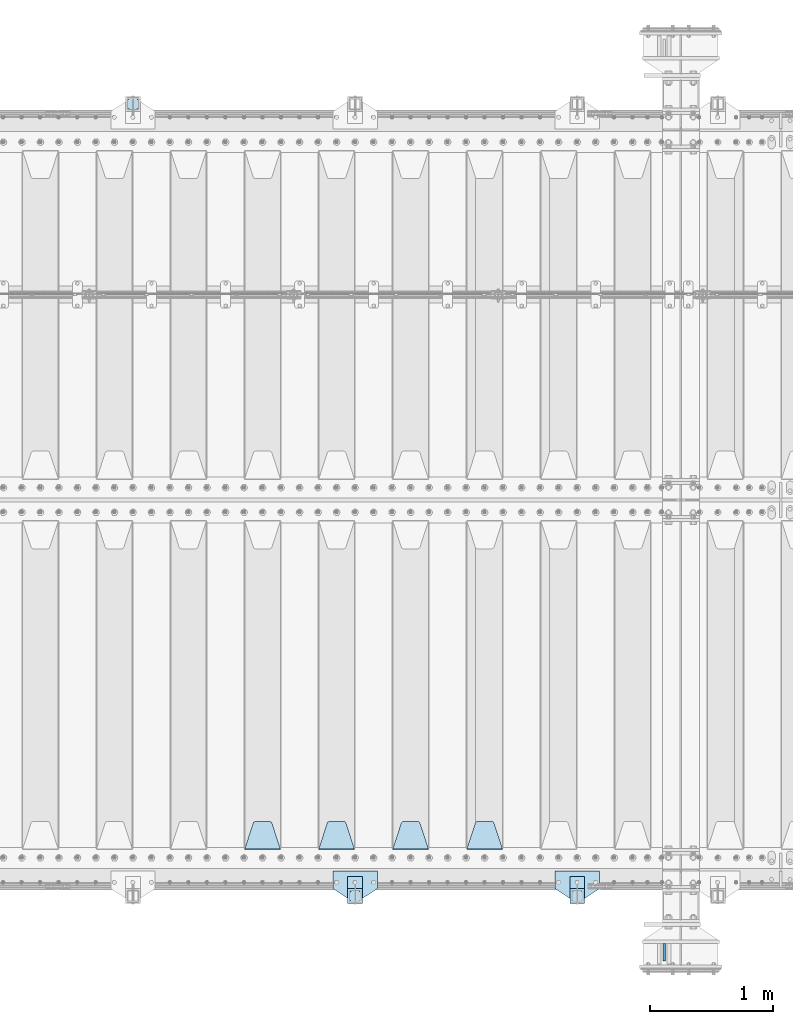
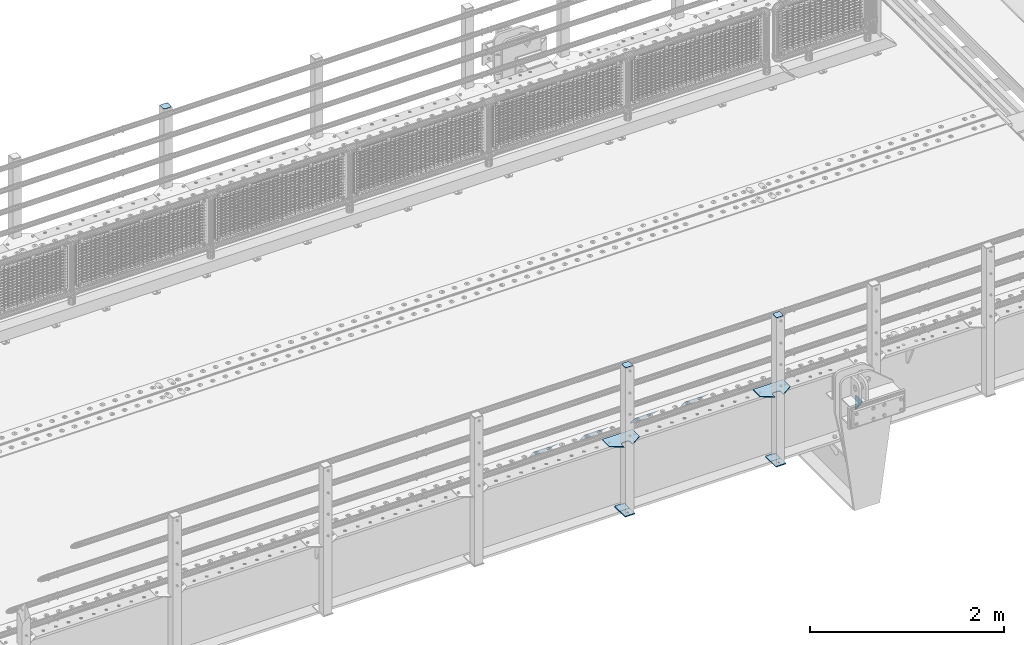
# One storey, part 164 of 193: 14 plates.
"""IFC2X3 building model written with IfcOpenShell, lengths in millimetres."""

from ifc_helpers import new_model, si_unit, frame, origin_with_axes, place, context, subcontext, project, spatial, faceted_brep, material, type_object, element, save


model = new_model("IFC2X3")

# Units and contexts
model_context = context("Model", 3, precision=1e-05, world=origin_with_axes())
body_context = subcontext(model_context, "Body", "Model", "MODEL_VIEW")
ifc_project = project(units=[si_unit("LENGTHUNIT", "METRE", prefix="MILLI"), si_unit("AREAUNIT", "SQUARE_METRE"), si_unit("VOLUMEUNIT", "CUBIC_METRE"), si_unit("MASSUNIT", "GRAM", prefix="KILO"), si_unit("TIMEUNIT", "SECOND"), si_unit("PLANEANGLEUNIT", "RADIAN"), si_unit("SOLIDANGLEUNIT", "STERADIAN"), si_unit("THERMODYNAMICTEMPERATUREUNIT", "DEGREE_CELSIUS"), si_unit("LUMINOUSINTENSITYUNIT", "LUMEN")], contexts=[model_context])

# Site, building, storey
site_placement = place(None, origin_with_axes())
site = spatial("IfcSite", under=ifc_project, at=site_placement, CompositionType="ELEMENT")
building_placement = place(site_placement, origin_with_axes())
building = spatial("IfcBuilding", under=site, at=building_placement, Name="Standard", CompositionType="ELEMENT")
storey_placement = place(building_placement, origin_with_axes())
storey = spatial("IfcBuildingStorey", under=building, at=storey_placement, Name="Undefined", CompositionType="ELEMENT", Elevation=0.0)

# Plates
ifc_material_1 = material(Name="STEEL/S355N")
plate_type_1 = type_object("IfcPlateType", PredefinedType="NOTDEFINED")
plate_1_placement = place(storey_placement, frame((-32195.5000001299, 23265.0000000057, -14.000018238301), z_axis=(0.0, 0.0, -1.0), x_axis=(0.0, 1.0, 0.0)))
element("IfcPlate", 1, at=plate_1_placement, inside=storey, type_object=plate_type_1, material=ifc_material_1, context=body_context, shape_type="Brep", body=[
    faceted_brep([(0.0, -10.0, 0.0), (140.0, -10.0, 180.0), (140.0, 10.0, 180.0), (0.0, 10.0, 0.0), (140.0, -10.0, -1.81898940354586e-12), (140.0, 10.0, -1.81898940354586e-12)], [[[0, 1, 2, 3]], [[1, 4, 5, 2]], [[4, 0, 3, 5]], [[5, 3, 2]], [[4, 1, 0]]]),
])
plate_type_2 = type_object("IfcPlateType", PredefinedType="NOTDEFINED")
plate_2_placement = place(storey_placement, frame((-33505.0, 24168.232233047, -1.76776695296758), z_axis=(0.0, 0.707106781186547, -0.707106781186548), x_axis=(-1.0, 0.0, 0.0)))
element("IfcPlate", 2, at=plate_2_placement, inside=storey, type_object=plate_type_2, material=ifc_material_1, context=body_context, shape_type="Brep", body=[
    faceted_brep([(0.0, -2.5, 0.0), (69.345504679477, -2.50000000000364, 300.171731424831), (69.345504679477, 2.49999999999636, 300.171731424831), (0.0, 2.5, 0.0), (70.9274061199576, -2.50000000000364, 304.897442415397), (70.9274061199576, 2.49999999999636, 304.897442415397), (73.3818627772307, -2.50000000000364, 309.234538108529), (73.3818627772307, 2.49999999999636, 309.234538108529), (76.6187032999551, -2.50000000000728, 313.023683126103), (76.6187032999551, 2.49999999999636, 313.023683126103), (80.5190132704993, -2.50000000000364, 316.125672595372), (80.5190132704993, 2.49999999999636, 316.125672595368), (84.9395038596849, -2.50000000000364, 318.426546230472), (84.9395038596849, 2.49999999999636, 318.426546230476), (89.7177759439219, -2.50000000000364, 319.841774983273), (89.7177759439219, 2.49999999999636, 319.841774983277), (94.678286292652, -2.50000000000364, 320.319366455074), (94.678286292652, 2.49999999999636, 320.319366455074), (195.321713707348, -2.50000000000364, 320.319366455074), (195.321713707348, 2.49999999999636, 320.319366455074), (200.282224056078, -2.50000000000364, 319.841774983273), (200.282224056078, 2.49999999999636, 319.841774983277), (205.060496140315, -2.50000000000364, 318.426546230472), (205.060496140315, 2.49999999999636, 318.426546230472), (209.480986729501, -2.50000000000364, 316.125672595372), (209.480986729501, 2.49999999999636, 316.125672595368), (213.381296700045, -2.50000000000728, 313.023683126103), (213.381296700045, 2.49999999999272, 313.023683126103), (216.618137222769, -2.50000000000364, 309.234538108525), (216.618137222769, 2.49999999999636, 309.234538108522), (219.072593880042, -2.50000000000364, 304.897442415397), (219.072593880042, 2.49999999999636, 304.897442415397), (220.654495320523, -2.50000000000364, 300.171731424831), (220.654495320523, 2.49999999999636, 300.171731424831), (290.0, -2.50000000000364, 0.0), (290.0, 2.49999999999636, 0.0)], [[[0, 1, 2, 3]], [[1, 4, 5, 2]], [[4, 6, 7, 5]], [[6, 8, 9, 7]], [[8, 10, 11, 9]], [[10, 12, 13, 11]], [[12, 14, 15, 13]], [[14, 16, 17, 15]], [[16, 18, 19, 17]], [[18, 20, 21, 19]], [[20, 22, 23, 21]], [[22, 24, 25, 23]], [[24, 26, 27, 25]], [[26, 28, 29, 27]], [[28, 30, 31, 29]], [[30, 32, 33, 31]], [[32, 34, 35, 33]], [[34, 0, 3, 35]], [[5, 7, 9, 11, 13, 15, 17, 19, 21, 23, 25, 27, 29, 31, 33, 35, 3, 2]], [[34, 32, 30, 28, 26, 24, 22, 20, 18, 16, 14, 12, 10, 8, 6, 4, 1, 0]]]),
])
plate_3_placement = place(storey_placement, frame((-34105.0, 24168.232233047, -1.76776695296758), z_axis=(0.0, 0.707106781186547, -0.707106781186548), x_axis=(-1.0, 0.0, 0.0)))
element("IfcPlate", 3, at=plate_3_placement, inside=storey, type_object=plate_type_2, material=ifc_material_1, context=body_context, shape_type="Brep", body=[
    faceted_brep([(0.0, -2.5, 0.0), (69.345504679477, -2.50000000000364, 300.171731424831), (69.345504679477, 2.49999999999636, 300.171731424831), (0.0, 2.5, 0.0), (70.9274061199576, -2.50000000000364, 304.897442415397), (70.9274061199576, 2.49999999999636, 304.897442415397), (73.3818627772307, -2.50000000000364, 309.234538108529), (73.3818627772307, 2.49999999999636, 309.234538108529), (76.6187032999551, -2.50000000000728, 313.023683126103), (76.6187032999551, 2.49999999999636, 313.023683126103), (80.5190132704993, -2.50000000000364, 316.125672595372), (80.5190132704993, 2.49999999999636, 316.125672595368), (84.9395038596849, -2.50000000000364, 318.426546230472), (84.9395038596849, 2.49999999999636, 318.426546230476), (89.7177759439219, -2.50000000000364, 319.841774983273), (89.7177759439219, 2.49999999999636, 319.841774983277), (94.678286292652, -2.50000000000364, 320.319366455074), (94.678286292652, 2.49999999999636, 320.319366455074), (195.321713707348, -2.50000000000364, 320.319366455074), (195.321713707348, 2.49999999999636, 320.319366455074), (200.282224056078, -2.50000000000364, 319.841774983273), (200.282224056078, 2.49999999999636, 319.841774983277), (205.060496140315, -2.50000000000364, 318.426546230472), (205.060496140315, 2.49999999999636, 318.426546230472), (209.480986729501, -2.50000000000364, 316.125672595372), (209.480986729501, 2.49999999999636, 316.125672595368), (213.381296700045, -2.50000000000728, 313.023683126103), (213.381296700045, 2.49999999999272, 313.023683126103), (216.618137222769, -2.50000000000364, 309.234538108525), (216.618137222769, 2.49999999999636, 309.234538108522), (219.072593880042, -2.50000000000364, 304.897442415397), (219.072593880042, 2.49999999999636, 304.897442415397), (220.654495320523, -2.50000000000364, 300.171731424831), (220.654495320523, 2.49999999999636, 300.171731424831), (290.0, -2.50000000000364, 0.0), (290.0, 2.49999999999636, 0.0)], [[[0, 1, 2, 3]], [[1, 4, 5, 2]], [[4, 6, 7, 5]], [[6, 8, 9, 7]], [[8, 10, 11, 9]], [[10, 12, 13, 11]], [[12, 14, 15, 13]], [[14, 16, 17, 15]], [[16, 18, 19, 17]], [[18, 20, 21, 19]], [[20, 22, 23, 21]], [[22, 24, 25, 23]], [[24, 26, 27, 25]], [[26, 28, 29, 27]], [[28, 30, 31, 29]], [[30, 32, 33, 31]], [[32, 34, 35, 33]], [[34, 0, 3, 35]], [[5, 7, 9, 11, 13, 15, 17, 19, 21, 23, 25, 27, 29, 31, 33, 35, 3, 2]], [[34, 32, 30, 28, 26, 24, 22, 20, 18, 16, 14, 12, 10, 8, 6, 4, 1, 0]]]),
])
plate_4_placement = place(storey_placement, frame((-34705.0, 24168.232233047, -1.76776695296758), z_axis=(0.0, 0.707106781186547, -0.707106781186548), x_axis=(-1.0, 0.0, 0.0)))
element("IfcPlate", 4, at=plate_4_placement, inside=storey, type_object=plate_type_2, material=ifc_material_1, context=body_context, shape_type="Brep", body=[
    faceted_brep([(0.0, -2.5, 0.0), (69.345504679477, -2.50000000000364, 300.171731424831), (69.345504679477, 2.49999999999636, 300.171731424831), (0.0, 2.5, 0.0), (70.9274061199576, -2.50000000000364, 304.897442415397), (70.9274061199576, 2.49999999999636, 304.897442415397), (73.3818627772307, -2.50000000000364, 309.234538108529), (73.3818627772307, 2.49999999999636, 309.234538108529), (76.6187032999551, -2.50000000000728, 313.023683126103), (76.6187032999551, 2.49999999999636, 313.023683126103), (80.5190132704993, -2.50000000000364, 316.125672595372), (80.5190132704993, 2.49999999999636, 316.125672595368), (84.9395038596849, -2.50000000000364, 318.426546230472), (84.9395038596849, 2.49999999999636, 318.426546230476), (89.7177759439219, -2.50000000000364, 319.841774983273), (89.7177759439219, 2.49999999999636, 319.841774983277), (94.678286292652, -2.50000000000364, 320.319366455074), (94.678286292652, 2.49999999999636, 320.319366455074), (195.321713707348, -2.50000000000364, 320.319366455074), (195.321713707348, 2.49999999999636, 320.319366455074), (200.282224056078, -2.50000000000364, 319.841774983273), (200.282224056078, 2.49999999999636, 319.841774983277), (205.060496140315, -2.50000000000364, 318.426546230472), (205.060496140315, 2.49999999999636, 318.426546230472), (209.480986729501, -2.50000000000364, 316.125672595372), (209.480986729501, 2.49999999999636, 316.125672595368), (213.381296700045, -2.50000000000728, 313.023683126103), (213.381296700045, 2.49999999999272, 313.023683126103), (216.618137222769, -2.50000000000364, 309.234538108525), (216.618137222769, 2.49999999999636, 309.234538108522), (219.072593880042, -2.50000000000364, 304.897442415397), (219.072593880042, 2.49999999999636, 304.897442415397), (220.654495320523, -2.50000000000364, 300.171731424831), (220.654495320523, 2.49999999999636, 300.171731424831), (290.0, -2.50000000000364, 0.0), (290.0, 2.49999999999636, 0.0)], [[[0, 1, 2, 3]], [[1, 4, 5, 2]], [[4, 6, 7, 5]], [[6, 8, 9, 7]], [[8, 10, 11, 9]], [[10, 12, 13, 11]], [[12, 14, 15, 13]], [[14, 16, 17, 15]], [[16, 18, 19, 17]], [[18, 20, 21, 19]], [[20, 22, 23, 21]], [[22, 24, 25, 23]], [[24, 26, 27, 25]], [[26, 28, 29, 27]], [[28, 30, 31, 29]], [[30, 32, 33, 31]], [[32, 34, 35, 33]], [[34, 0, 3, 35]], [[5, 7, 9, 11, 13, 15, 17, 19, 21, 23, 25, 27, 29, 31, 33, 35, 3, 2]], [[34, 32, 30, 28, 26, 24, 22, 20, 18, 16, 14, 12, 10, 8, 6, 4, 1, 0]]]),
])
plate_5_placement = place(storey_placement, frame((-35305.0, 24168.232233047, -1.76776695296758), z_axis=(0.0, 0.707106781186547, -0.707106781186548), x_axis=(-1.0, 0.0, 0.0)))
element("IfcPlate", 5, at=plate_5_placement, inside=storey, type_object=plate_type_2, material=ifc_material_1, context=body_context, shape_type="Brep", body=[
    faceted_brep([(0.0, -2.5, 0.0), (69.345504679477, -2.50000000000364, 300.171731424831), (69.345504679477, 2.49999999999636, 300.171731424831), (0.0, 2.5, 0.0), (70.9274061199576, -2.50000000000364, 304.897442415397), (70.9274061199576, 2.49999999999636, 304.897442415397), (73.3818627772307, -2.50000000000364, 309.234538108529), (73.3818627772307, 2.49999999999636, 309.234538108529), (76.6187032999551, -2.50000000000728, 313.023683126103), (76.6187032999551, 2.49999999999636, 313.023683126103), (80.5190132704993, -2.50000000000364, 316.125672595372), (80.5190132704993, 2.49999999999636, 316.125672595368), (84.9395038596849, -2.50000000000364, 318.426546230472), (84.9395038596849, 2.49999999999636, 318.426546230476), (89.7177759439219, -2.50000000000364, 319.841774983273), (89.7177759439219, 2.49999999999636, 319.841774983277), (94.678286292652, -2.50000000000364, 320.319366455074), (94.678286292652, 2.49999999999636, 320.319366455074), (195.321713707348, -2.50000000000364, 320.319366455074), (195.321713707348, 2.49999999999636, 320.319366455074), (200.282224056078, -2.50000000000364, 319.841774983273), (200.282224056078, 2.49999999999636, 319.841774983277), (205.060496140315, -2.50000000000364, 318.426546230472), (205.060496140315, 2.49999999999636, 318.426546230472), (209.480986729501, -2.50000000000364, 316.125672595372), (209.480986729501, 2.49999999999636, 316.125672595368), (213.381296700045, -2.50000000000728, 313.023683126103), (213.381296700045, 2.49999999999272, 313.023683126103), (216.618137222769, -2.50000000000364, 309.234538108525), (216.618137222769, 2.49999999999636, 309.234538108522), (219.072593880042, -2.50000000000364, 304.897442415397), (219.072593880042, 2.49999999999636, 304.897442415397), (220.654495320523, -2.50000000000364, 300.171731424831), (220.654495320523, 2.49999999999636, 300.171731424831), (290.0, -2.50000000000364, 0.0), (290.0, 2.49999999999636, 0.0)], [[[0, 1, 2, 3]], [[1, 4, 5, 2]], [[4, 6, 7, 5]], [[6, 8, 9, 7]], [[8, 10, 11, 9]], [[10, 12, 13, 11]], [[12, 14, 15, 13]], [[14, 16, 17, 15]], [[16, 18, 19, 17]], [[18, 20, 21, 19]], [[20, 22, 23, 21]], [[22, 24, 25, 23]], [[24, 26, 27, 25]], [[26, 28, 29, 27]], [[28, 30, 31, 29]], [[30, 32, 33, 31]], [[32, 34, 35, 33]], [[34, 0, 3, 35]], [[5, 7, 9, 11, 13, 15, 17, 19, 21, 23, 25, 27, 29, 31, 33, 35, 3, 2]], [[34, 32, 30, 28, 26, 24, 22, 20, 18, 16, 14, 12, 10, 8, 6, 4, 1, 0]]]),
])
ifc_material_2 = material(Name="STEEL/S355J2")
plate_type_3 = type_object("IfcPlateType", PredefinedType="NOTDEFINED")
plate_6_placement = place(storey_placement, frame((-32720.0, 23995.0, 5.00000000004911), z_axis=(0.0, -1.0, 0.0), x_axis=(-1.0, 0.0, 0.0)))
element("IfcPlate", 6, at=plate_6_placement, inside=storey, type_object=plate_type_3, material=ifc_material_2, context=body_context, shape_type="Brep", body=[
    faceted_brep([(0.0, -5.0, 0.0), (2.31396552408114e-06, -5.0, 145.0), (2.31396552408114e-06, 5.0, 145.0), (0.0, 5.0, 0.0), (130.0, -5.0, 230.0), (130.0, 5.0, 230.0), (130.0, -5.0, 180.0), (130.0, 5.0, 180.0), (130.48036798992, -5.0, 175.122741949595), (130.48036798992, 5.0, 175.122741949595), (131.903011687216, -5.0, 170.432914190871), (131.903011687216, 5.0, 170.432914190871), (134.213259692435, -5.0, 166.110744174512), (134.213259692435, 5.0, 166.110744174512), (137.322330470335, -5.0, 162.322330470335), (137.322330470335, 5.0, 162.322330470335), (141.110744174512, -5.0, 159.213259692435), (141.110744174512, 5.0, 159.213259692435), (145.432914190871, -5.0, 156.903011687216), (145.432914190871, 5.0, 156.903011687216), (150.122741949595, -5.0, 155.48036798992), (150.122741949595, 5.0, 155.48036798992), (155.0, -5.0, 155.0), (155.0, 5.0, 155.0), (205.0, -5.0, 155.0), (205.0, 5.0, 155.0), (209.877258050405, -5.0, 155.48036798992), (209.877258050405, 5.0, 155.48036798992), (214.567085809129, -5.0, 156.903011687216), (214.567085809129, 5.0, 156.903011687216), (218.889255825488, -5.0, 159.213259692435), (218.889255825488, 5.0, 159.213259692435), (222.677669529665, -5.0, 162.322330470335), (222.677669529665, 5.0, 162.322330470335), (225.786740307565, -5.0, 166.110744174512), (225.786740307565, 5.0, 166.110744174512), (228.096988312784, -5.0, 170.432914190871), (228.096988312784, 5.0, 170.432914190871), (229.51963201008, -5.0, 175.122741949595), (229.51963201008, 5.0, 175.122741949595), (230.0, -5.0, 180.0), (230.0, 5.0, 180.0), (230.0, -5.0, 230.0), (230.0, 5.0, 230.0), (360.0, -5.0, 145.0), (360.0, 5.0, 145.0), (360.0, -5.0, -7.27595761418343e-12), (360.0, 5.0, -7.27595761418343e-12)], [[[0, 1, 2, 3]], [[1, 4, 5, 2]], [[4, 6, 7, 5]], [[6, 8, 9, 7]], [[8, 10, 11, 9]], [[10, 12, 13, 11]], [[12, 14, 15, 13]], [[14, 16, 17, 15]], [[16, 18, 19, 17]], [[18, 20, 21, 19]], [[20, 22, 23, 21]], [[22, 24, 25, 23]], [[24, 26, 27, 25]], [[26, 28, 29, 27]], [[28, 30, 31, 29]], [[30, 32, 33, 31]], [[32, 34, 35, 33]], [[34, 36, 37, 35]], [[36, 38, 39, 37]], [[38, 40, 41, 39]], [[40, 42, 43, 41]], [[42, 44, 45, 43]], [[44, 46, 47, 45]], [[46, 0, 3, 47]], [[5, 7, 9, 11, 13, 15, 17, 19, 21, 23, 25, 27, 29, 31, 33, 35, 37, 39, 41, 43, 45, 47, 3, 2]], [[46, 44, 42, 40, 38, 36, 34, 32, 30, 28, 26, 24, 22, 20, 18, 16, 14, 12, 10, 8, 6, 4, 1, 0]]]),
])
plate_7_placement = place(storey_placement, frame((-34520.0, 23995.0, 5.00000000004911), z_axis=(0.0, -1.0, 0.0), x_axis=(-1.0, 0.0, 0.0)))
element("IfcPlate", 7, at=plate_7_placement, inside=storey, type_object=plate_type_3, material=ifc_material_2, context=body_context, shape_type="Brep", body=[
    faceted_brep([(0.0, -5.0, 0.0), (2.31396552408114e-06, -5.0, 145.0), (2.31396552408114e-06, 5.0, 145.0), (0.0, 5.0, 0.0), (130.0, -5.0, 230.0), (130.0, 5.0, 230.0), (130.0, -5.0, 180.0), (130.0, 5.0, 180.0), (130.48036798992, -5.0, 175.122741949595), (130.48036798992, 5.0, 175.122741949595), (131.903011687216, -5.0, 170.432914190871), (131.903011687216, 5.0, 170.432914190871), (134.213259692435, -5.0, 166.110744174512), (134.213259692435, 5.0, 166.110744174512), (137.322330470335, -5.0, 162.322330470335), (137.322330470335, 5.0, 162.322330470335), (141.110744174512, -5.0, 159.213259692435), (141.110744174512, 5.0, 159.213259692435), (145.432914190871, -5.0, 156.903011687216), (145.432914190871, 5.0, 156.903011687216), (150.122741949595, -5.0, 155.48036798992), (150.122741949595, 5.0, 155.48036798992), (155.0, -5.0, 155.0), (155.0, 5.0, 155.0), (205.0, -5.0, 155.0), (205.0, 5.0, 155.0), (209.877258050405, -5.0, 155.48036798992), (209.877258050405, 5.0, 155.48036798992), (214.567085809129, -5.0, 156.903011687216), (214.567085809129, 5.0, 156.903011687216), (218.889255825488, -5.0, 159.213259692435), (218.889255825488, 5.0, 159.213259692435), (222.677669529665, -5.0, 162.322330470335), (222.677669529665, 5.0, 162.322330470335), (225.786740307565, -5.0, 166.110744174512), (225.786740307565, 5.0, 166.110744174512), (228.096988312784, -5.0, 170.432914190871), (228.096988312784, 5.0, 170.432914190871), (229.51963201008, -5.0, 175.122741949595), (229.51963201008, 5.0, 175.122741949595), (230.0, -5.0, 180.0), (230.0, 5.0, 180.0), (230.0, -5.0, 230.0), (230.0, 5.0, 230.0), (360.0, -5.0, 145.0), (360.0, 5.0, 145.0), (360.0, -5.0, -7.27595761418343e-12), (360.0, 5.0, -7.27595761418343e-12)], [[[0, 1, 2, 3]], [[1, 4, 5, 2]], [[4, 6, 7, 5]], [[6, 8, 9, 7]], [[8, 10, 11, 9]], [[10, 12, 13, 11]], [[12, 14, 15, 13]], [[14, 16, 17, 15]], [[16, 18, 19, 17]], [[18, 20, 21, 19]], [[20, 22, 23, 21]], [[22, 24, 25, 23]], [[24, 26, 27, 25]], [[26, 28, 29, 27]], [[28, 30, 31, 29]], [[30, 32, 33, 31]], [[32, 34, 35, 33]], [[34, 36, 37, 35]], [[36, 38, 39, 37]], [[38, 40, 41, 39]], [[40, 42, 43, 41]], [[42, 44, 45, 43]], [[44, 46, 47, 45]], [[46, 0, 3, 47]], [[5, 7, 9, 11, 13, 15, 17, 19, 21, 23, 25, 27, 29, 31, 33, 35, 37, 39, 41, 43, 45, 47, 3, 2]], [[46, 44, 42, 40, 38, 36, 34, 32, 30, 28, 26, 24, 22, 20, 18, 16, 14, 12, 10, 8, 6, 4, 1, 0]]]),
])
plate_type_4 = type_object("IfcPlateType", PredefinedType="NOTDEFINED")
for number, where, z_axis, x_axis in (
    (8, (-32840.0000000001, 23949.9999999998, -850.000000000002), (0.0, -1.0, 0.0), (-1.0, 0.0, 0.0)),
    (9, (-34640.0000000001, 23949.9999999998, -850.000000000002), (0.0, -1.0, 0.0), (-1.0, 0.0, 0.0)),
):
    element("IfcPlate", number, at=place(storey_placement, frame(where, z_axis=z_axis, x_axis=x_axis)), inside=storey, type_object=plate_type_4, material=ifc_material_2, context=body_context, shape_type="Brep", body=[
        faceted_brep([(53.6360389691836, -5.0, 176.363961030467), (53.6360389691836, 5.0, 176.363961030467), (59.9999999998618, 5.0, 178.999999999789), (59.9999999998618, -5.0, 178.999999999789), (66.3639610305399, 5.0, 176.363961030467), (66.3639610305399, -5.0, 176.363961030467), (68.9999999998618, 5.0, 169.999999999789), (68.9999999998618, -5.0, 169.999999999789), (66.3639610305399, 5.0, 163.636038969111), (66.3639610305399, -5.0, 163.636038969111), (59.9999999998618, 5.0, 160.999999999789), (59.9999999998618, -5.0, 160.999999999789), (53.6360389691836, 5.0, 163.636038969111), (53.6360389691836, -5.0, 163.636038969111), (50.9999999998618, 5.0, 169.999999999789), (50.9999999998618, -5.0, 169.999999999789), (120.0, -5.0, 0.0), (120.0, -5.0, 220.0), (0.0, -5.0, 220.0), (0.0, -5.0, 0.0), (0.0, 5.0, 0.0), (120.0, 5.0, 0.0), (120.0, 5.0, 220.0), (0.0, 5.0, 220.0)], [[[0, 1, 2, 3]], [[3, 2, 4, 5]], [[5, 4, 6, 7]], [[7, 6, 8, 9]], [[9, 8, 10, 11]], [[11, 10, 12, 13]], [[13, 12, 14, 15]], [[15, 14, 1, 0]], [[16, 17, 18, 19], [11, 13, 15, 0, 3, 5, 7, 9]], [[16, 19, 20, 21]], [[17, 16, 21, 22]], [[18, 17, 22, 23]], [[19, 18, 23, 20]], [[22, 21, 20, 23], [2, 1, 14, 12, 10, 8, 6, 4]]]),
    ])
plate_type_5 = type_object("IfcPlateType", PredefinedType="NOTDEFINED")
plate_8_placement = place(storey_placement, frame((-36455.9999999999, 30166.0000000002, 1012.50000000001), z_axis=(0.0, 1.0, 0.0), x_axis=(-1.0, 0.0, 0.0)))
element("IfcPlate", 10, at=plate_8_placement, inside=storey, type_object=plate_type_5, material=ifc_material_2, context=body_context, shape_type="Brep", body=[
    faceted_brep([(0.0, -2.5, 19.0), (0.0, -2.5, 69.0), (0.0, 2.5, 69.0), (0.0, 2.5, 19.0), (0.476369668544066, -2.5, 73.2278977451715), (0.476369668544066, 2.5, 73.2278977451715), (1.88159150985302, -2.5, 77.2437910432345), (1.88159150985302, 2.5, 77.2437910432345), (4.14520183310742, -2.5, 80.8463062353148), (4.14520183310742, 2.5, 80.8463062353148), (7.15369376468516, -2.5, 83.8547981668926), (7.15369376468516, 2.5, 83.8547981668926), (10.7562089567655, -2.5, 86.118408490147), (10.7562089567655, 2.5, 86.118408490147), (14.7721022548285, -2.5, 87.5236303314559), (14.7721022548285, 2.5, 87.5236303314559), (19.0, -2.5, 88.0), (19.0, 2.5, 88.0), (69.0, -2.5, 88.0), (69.0, 2.5, 88.0), (73.2278977451715, -2.5, 87.5236303314559), (73.2278977451715, 2.5, 87.5236303314559), (77.2437910432345, -2.5, 86.118408490147), (77.2437910432345, 2.5, 86.118408490147), (80.8463062353148, -2.5, 83.8547981668926), (80.8463062353148, 2.5, 83.8547981668926), (83.8547981668926, -2.5, 80.8463062353148), (83.8547981668926, 2.5, 80.8463062353148), (86.118408490147, -2.5, 77.2437910432345), (86.118408490147, 2.5, 77.2437910432345), (87.5236303314559, -2.5, 73.2278977451715), (87.5236303314559, 2.5, 73.2278977451715), (88.0, -2.5, 69.0), (88.0, 2.5, 69.0), (88.0, -2.5, 19.0), (88.0, 2.5, 19.0), (87.5236303314559, -2.5, 14.7721022548285), (87.5236303314559, 2.5, 14.7721022548285), (86.118408490147, -2.5, 10.7562089567655), (86.118408490147, 2.5, 10.7562089567655), (83.8547981668926, -2.5, 7.15369376468516), (83.8547981668926, 2.5, 7.15369376468516), (80.8463062353148, -2.5, 4.14520183310742), (80.8463062353148, 2.5, 4.14520183310742), (77.2437910432345, -2.5, 1.88159150985302), (77.2437910432345, 2.5, 1.88159150985302), (73.2278977451715, -2.5, 0.476369668544066), (73.2278977451715, 2.5, 0.476369668544066), (69.0, -2.5, 0.0), (69.0, 2.5, 0.0), (19.0, -2.5, 0.0), (19.0, 2.5, 0.0), (14.7721022548285, -2.5, 0.476369668544066), (14.7721022548285, 2.5, 0.476369668544066), (10.7562089567655, -2.5, 1.88159150985302), (10.7562089567655, 2.5, 1.88159150985302), (7.15369376468516, -2.5, 4.14520183310742), (7.15369376468516, 2.5, 4.14520183310742), (4.14520183310742, -2.5, 7.15369376468516), (4.14520183310742, 2.5, 7.15369376468516), (1.88159150985302, -2.5, 10.7562089567655), (1.88159150985302, 2.5, 10.7562089567655), (0.476369668544066, -2.5, 14.7721022548285), (0.476369668544066, 2.5, 14.7721022548285)], [[[0, 1, 2, 3]], [[1, 4, 5, 2]], [[4, 6, 7, 5]], [[6, 8, 9, 7]], [[8, 10, 11, 9]], [[10, 12, 13, 11]], [[12, 14, 15, 13]], [[14, 16, 17, 15]], [[16, 18, 19, 17]], [[18, 20, 21, 19]], [[20, 22, 23, 21]], [[22, 24, 25, 23]], [[24, 26, 27, 25]], [[26, 28, 29, 27]], [[28, 30, 31, 29]], [[30, 32, 33, 31]], [[32, 34, 35, 33]], [[34, 36, 37, 35]], [[36, 38, 39, 37]], [[38, 40, 41, 39]], [[40, 42, 43, 41]], [[42, 44, 45, 43]], [[44, 46, 47, 45]], [[46, 48, 49, 47]], [[48, 50, 51, 49]], [[50, 52, 53, 51]], [[52, 54, 55, 53]], [[54, 56, 57, 55]], [[56, 58, 59, 57]], [[58, 60, 61, 59]], [[60, 62, 63, 61]], [[62, 0, 3, 63]], [[5, 7, 9, 11, 13, 15, 17, 19, 21, 23, 25, 27, 29, 31, 33, 35, 37, 39, 41, 43, 45, 47, 49, 51, 53, 55, 57, 59, 61, 63, 3, 2]], [[62, 60, 58, 56, 54, 52, 50, 48, 46, 44, 42, 40, 38, 36, 34, 32, 30, 28, 26, 24, 22, 20, 18, 16, 14, 12, 10, 8, 6, 4, 1, 0]]]),
])
plate_9_placement = place(storey_placement, frame((-32944.0000000001, 23833.9999999998, 1012.50000000001), z_axis=(0.0, -1.0, 0.0), x_axis=(1.0, 0.0, 0.0)))
element("IfcPlate", 11, at=plate_9_placement, inside=storey, type_object=plate_type_5, material=ifc_material_2, context=body_context, shape_type="Brep", body=[
    faceted_brep([(0.0, -2.5, 19.0), (0.0, -2.5, 69.0), (0.0, 2.5, 69.0), (0.0, 2.5, 19.0), (0.476369668544066, -2.5, 73.2278977451715), (0.476369668544066, 2.5, 73.2278977451715), (1.88159150985302, -2.5, 77.2437910432345), (1.88159150985302, 2.5, 77.2437910432345), (4.14520183310742, -2.5, 80.8463062353148), (4.14520183310742, 2.5, 80.8463062353148), (7.15369376468516, -2.5, 83.8547981668926), (7.15369376468516, 2.5, 83.8547981668926), (10.7562089567655, -2.5, 86.118408490147), (10.7562089567655, 2.5, 86.118408490147), (14.7721022548285, -2.5, 87.5236303314559), (14.7721022548285, 2.5, 87.5236303314559), (19.0, -2.5, 88.0), (19.0, 2.5, 88.0), (69.0, -2.5, 88.0), (69.0, 2.5, 88.0), (73.2278977451715, -2.5, 87.5236303314559), (73.2278977451715, 2.5, 87.5236303314559), (77.2437910432345, -2.5, 86.118408490147), (77.2437910432345, 2.5, 86.118408490147), (80.8463062353148, -2.5, 83.8547981668926), (80.8463062353148, 2.5, 83.8547981668926), (83.8547981668926, -2.5, 80.8463062353148), (83.8547981668926, 2.5, 80.8463062353148), (86.118408490147, -2.5, 77.2437910432345), (86.118408490147, 2.5, 77.2437910432345), (87.5236303314559, -2.5, 73.2278977451715), (87.5236303314559, 2.5, 73.2278977451715), (88.0, -2.5, 69.0), (88.0, 2.5, 69.0), (88.0, -2.5, 19.0), (88.0, 2.5, 19.0), (87.5236303314559, -2.5, 14.7721022548285), (87.5236303314559, 2.5, 14.7721022548285), (86.118408490147, -2.5, 10.7562089567655), (86.118408490147, 2.5, 10.7562089567655), (83.8547981668926, -2.5, 7.15369376468516), (83.8547981668926, 2.5, 7.15369376468516), (80.8463062353148, -2.5, 4.14520183310742), (80.8463062353148, 2.5, 4.14520183310742), (77.2437910432345, -2.5, 1.88159150985302), (77.2437910432345, 2.5, 1.88159150985302), (73.2278977451715, -2.5, 0.476369668544066), (73.2278977451715, 2.5, 0.476369668544066), (69.0, -2.5, 0.0), (69.0, 2.5, 0.0), (19.0, -2.5, 0.0), (19.0, 2.5, 0.0), (14.7721022548285, -2.5, 0.476369668544066), (14.7721022548285, 2.5, 0.476369668544066), (10.7562089567655, -2.5, 1.88159150985302), (10.7562089567655, 2.5, 1.88159150985302), (7.15369376468516, -2.5, 4.14520183310742), (7.15369376468516, 2.5, 4.14520183310742), (4.14520183310742, -2.5, 7.15369376468516), (4.14520183310742, 2.5, 7.15369376468516), (1.88159150985302, -2.5, 10.7562089567655), (1.88159150985302, 2.5, 10.7562089567655), (0.476369668544066, -2.5, 14.7721022548285), (0.476369668544066, 2.5, 14.7721022548285)], [[[0, 1, 2, 3]], [[1, 4, 5, 2]], [[4, 6, 7, 5]], [[6, 8, 9, 7]], [[8, 10, 11, 9]], [[10, 12, 13, 11]], [[12, 14, 15, 13]], [[14, 16, 17, 15]], [[16, 18, 19, 17]], [[18, 20, 21, 19]], [[20, 22, 23, 21]], [[22, 24, 25, 23]], [[24, 26, 27, 25]], [[26, 28, 29, 27]], [[28, 30, 31, 29]], [[30, 32, 33, 31]], [[32, 34, 35, 33]], [[34, 36, 37, 35]], [[36, 38, 39, 37]], [[38, 40, 41, 39]], [[40, 42, 43, 41]], [[42, 44, 45, 43]], [[44, 46, 47, 45]], [[46, 48, 49, 47]], [[48, 50, 51, 49]], [[50, 52, 53, 51]], [[52, 54, 55, 53]], [[54, 56, 57, 55]], [[56, 58, 59, 57]], [[58, 60, 61, 59]], [[60, 62, 63, 61]], [[62, 0, 3, 63]], [[5, 7, 9, 11, 13, 15, 17, 19, 21, 23, 25, 27, 29, 31, 33, 35, 37, 39, 41, 43, 45, 47, 49, 51, 53, 55, 57, 59, 61, 63, 3, 2]], [[62, 60, 58, 56, 54, 52, 50, 48, 46, 44, 42, 40, 38, 36, 34, 32, 30, 28, 26, 24, 22, 20, 18, 16, 14, 12, 10, 8, 6, 4, 1, 0]]]),
])
plate_10_placement = place(storey_placement, frame((-34744.0000000001, 23833.9999999998, 1012.50000000001), z_axis=(0.0, -1.0, 0.0), x_axis=(1.0, 0.0, 0.0)))
element("IfcPlate", 12, at=plate_10_placement, inside=storey, type_object=plate_type_5, material=ifc_material_2, context=body_context, shape_type="Brep", body=[
    faceted_brep([(0.0, -2.5, 19.0), (0.0, -2.5, 69.0), (0.0, 2.5, 69.0), (0.0, 2.5, 19.0), (0.476369668544066, -2.5, 73.2278977451715), (0.476369668544066, 2.5, 73.2278977451715), (1.88159150985302, -2.5, 77.2437910432345), (1.88159150985302, 2.5, 77.2437910432345), (4.14520183310742, -2.5, 80.8463062353148), (4.14520183310742, 2.5, 80.8463062353148), (7.15369376468516, -2.5, 83.8547981668926), (7.15369376468516, 2.5, 83.8547981668926), (10.7562089567655, -2.5, 86.118408490147), (10.7562089567655, 2.5, 86.118408490147), (14.7721022548285, -2.5, 87.5236303314559), (14.7721022548285, 2.5, 87.5236303314559), (19.0, -2.5, 88.0), (19.0, 2.5, 88.0), (69.0, -2.5, 88.0), (69.0, 2.5, 88.0), (73.2278977451715, -2.5, 87.5236303314559), (73.2278977451715, 2.5, 87.5236303314559), (77.2437910432345, -2.5, 86.118408490147), (77.2437910432345, 2.5, 86.118408490147), (80.8463062353148, -2.5, 83.8547981668926), (80.8463062353148, 2.5, 83.8547981668926), (83.8547981668926, -2.5, 80.8463062353148), (83.8547981668926, 2.5, 80.8463062353148), (86.118408490147, -2.5, 77.2437910432345), (86.118408490147, 2.5, 77.2437910432345), (87.5236303314559, -2.5, 73.2278977451715), (87.5236303314559, 2.5, 73.2278977451715), (88.0, -2.5, 69.0), (88.0, 2.5, 69.0), (88.0, -2.5, 19.0), (88.0, 2.5, 19.0), (87.5236303314559, -2.5, 14.7721022548285), (87.5236303314559, 2.5, 14.7721022548285), (86.118408490147, -2.5, 10.7562089567655), (86.118408490147, 2.5, 10.7562089567655), (83.8547981668926, -2.5, 7.15369376468516), (83.8547981668926, 2.5, 7.15369376468516), (80.8463062353148, -2.5, 4.14520183310742), (80.8463062353148, 2.5, 4.14520183310742), (77.2437910432345, -2.5, 1.88159150985302), (77.2437910432345, 2.5, 1.88159150985302), (73.2278977451715, -2.5, 0.476369668544066), (73.2278977451715, 2.5, 0.476369668544066), (69.0, -2.5, 0.0), (69.0, 2.5, 0.0), (19.0, -2.5, 0.0), (19.0, 2.5, 0.0), (14.7721022548285, -2.5, 0.476369668544066), (14.7721022548285, 2.5, 0.476369668544066), (10.7562089567655, -2.5, 1.88159150985302), (10.7562089567655, 2.5, 1.88159150985302), (7.15369376468516, -2.5, 4.14520183310742), (7.15369376468516, 2.5, 4.14520183310742), (4.14520183310742, -2.5, 7.15369376468516), (4.14520183310742, 2.5, 7.15369376468516), (1.88159150985302, -2.5, 10.7562089567655), (1.88159150985302, 2.5, 10.7562089567655), (0.476369668544066, -2.5, 14.7721022548285), (0.476369668544066, 2.5, 14.7721022548285)], [[[0, 1, 2, 3]], [[1, 4, 5, 2]], [[4, 6, 7, 5]], [[6, 8, 9, 7]], [[8, 10, 11, 9]], [[10, 12, 13, 11]], [[12, 14, 15, 13]], [[14, 16, 17, 15]], [[16, 18, 19, 17]], [[18, 20, 21, 19]], [[20, 22, 23, 21]], [[22, 24, 25, 23]], [[24, 26, 27, 25]], [[26, 28, 29, 27]], [[28, 30, 31, 29]], [[30, 32, 33, 31]], [[32, 34, 35, 33]], [[34, 36, 37, 35]], [[36, 38, 39, 37]], [[38, 40, 41, 39]], [[40, 42, 43, 41]], [[42, 44, 45, 43]], [[44, 46, 47, 45]], [[46, 48, 49, 47]], [[48, 50, 51, 49]], [[50, 52, 53, 51]], [[52, 54, 55, 53]], [[54, 56, 57, 55]], [[56, 58, 59, 57]], [[58, 60, 61, 59]], [[60, 62, 63, 61]], [[62, 0, 3, 63]], [[5, 7, 9, 11, 13, 15, 17, 19, 21, 23, 25, 27, 29, 31, 33, 35, 37, 39, 41, 43, 45, 47, 49, 51, 53, 55, 57, 59, 61, 63, 3, 2]], [[62, 60, 58, 56, 54, 52, 50, 48, 46, 44, 42, 40, 38, 36, 34, 32, 30, 28, 26, 24, 22, 20, 18, 16, 14, 12, 10, 8, 6, 4, 1, 0]]]),
])
plate_type_6 = type_object("IfcPlateType", PredefinedType="NOTDEFINED")
for number, where, z_axis, x_axis in (
    (13, (-32840.0000000001, 23949.9999999998, -857.500000000002), (0.0, -1.0, 0.0), (-1.0, 0.0, 0.0)),
    (14, (-34640.0000000001, 23949.9999999998, -857.500000000002), (0.0, -1.0, 0.0), (-1.0, 0.0, 0.0)),
):
    element("IfcPlate", number, at=place(storey_placement, frame(where, z_axis=z_axis, x_axis=x_axis)), inside=storey, type_object=plate_type_6, material=ifc_material_2, context=body_context, shape_type="Brep", body=[
        faceted_brep([(0.0, -2.5, 0.0), (0.0, -2.5, 100.0), (0.0, 2.5, 100.0), (0.0, 2.5, 0.0), (120.0, -2.5, 100.0), (120.0, 2.5, 100.0), (120.0, -2.5, 0.0), (120.0, 2.5, 0.0)], [[[0, 1, 2, 3]], [[1, 4, 5, 2]], [[4, 6, 7, 5]], [[6, 0, 3, 7]], [[5, 7, 3, 2]], [[6, 4, 1, 0]]]),
    ])

save(model, "model.ifc")
